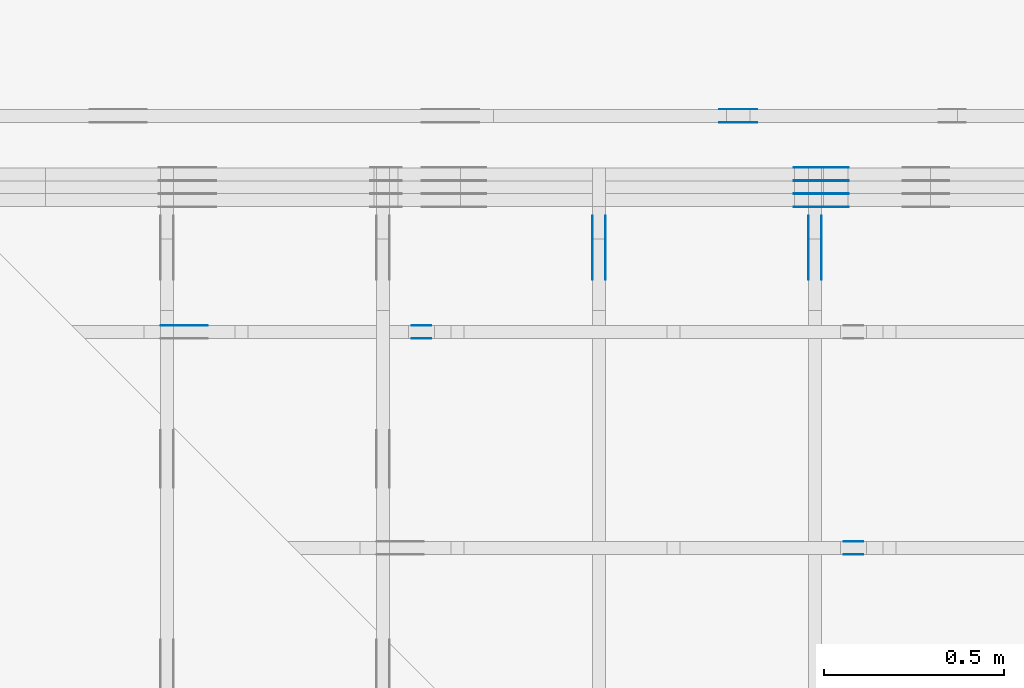
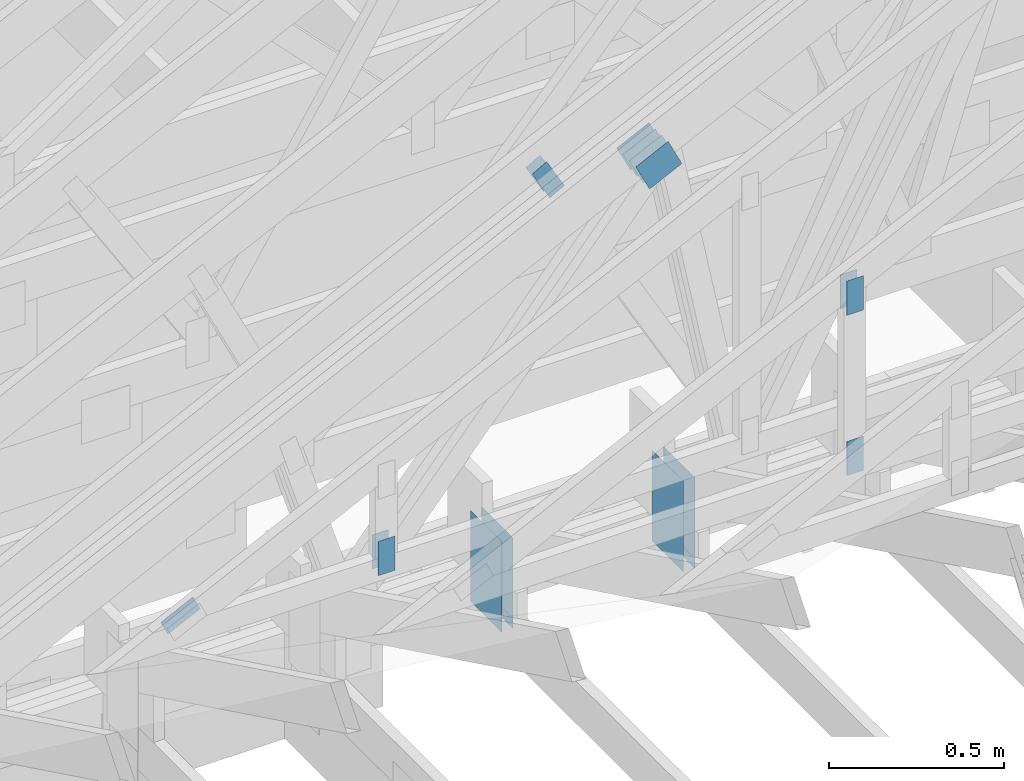
# One storey, part 101 of 159: 18 plates, 6 elements without a shape of their own.
"""IFC2X3 building model written with IfcOpenShell, lengths in millimetres."""

from ifc_helpers import new_model, si_unit, frame, origin, origin_with_axes, origin_2d, place, context, project, spatial, faceted_brep, element, aggregate, save


model = new_model("IFC2X3")

# Units and contexts
model_context = context("Model", 3, precision=1e-05, world=origin())
plan_context = context("Plan", 2, precision=1e-05, world=origin_2d())
ifc_project = project(units=[si_unit("LENGTHUNIT", "METRE", prefix="MILLI"), si_unit("AREAUNIT", "SQUARE_METRE"), si_unit("VOLUMEUNIT", "CUBIC_METRE"), si_unit("SOLIDANGLEUNIT", "STERADIAN"), si_unit("PLANEANGLEUNIT", "RADIAN"), si_unit("MASSUNIT", "GRAM"), si_unit("TIMEUNIT", "SECOND"), si_unit("THERMODYNAMICTEMPERATUREUNIT", "DEGREE_CELSIUS"), si_unit("LUMINOUSINTENSITYUNIT", "LUMEN")], contexts=[model_context, plan_context])

# Site, building, storey
site_placement = place(None, origin_with_axes())
site = spatial("IfcSite", under=ifc_project, at=site_placement, CompositionType="ELEMENT")
building_placement = place(site_placement, origin_with_axes())
building = spatial("IfcBuilding", under=site, at=building_placement, Name="Plan 1", CompositionType="ELEMENT")
storey_placement = place(building_placement, origin_with_axes())
storey = spatial("IfcBuildingStorey", under=building, at=storey_placement, Name="Etasje 1", CompositionType="ELEMENT", Elevation=0.0)

# Assembly, plates
assembly_1_placement = place(storey_placement, frame((10700.012663101485, 8801.999999990367, 0.0), z_axis=(0.0, -1.0, 6.123031769111886e-17), x_axis=(1.0, 0.0, 0.0)))
assembly_1 = element("IfcElementAssembly", 1, at=assembly_1_placement, inside=storey, Name="T8 (1)", AssemblyPlace="FACTORY", PredefinedType="TRUSS")
plate_1_placement = place(assembly_1_placement, frame((2640.9558752866787, 1642.1270385716039, 0.0), z_axis=(0.0, 0.0, 1.0), x_axis=(-0.898794046299167, -0.4383711467890773, 0.0)))
plate_1 = element("IfcPlate", 2, at=plate_1_placement, Name="GNT100S 103x119", context=model_context, shape_type="Brep", body=[
    faceted_brep([(119.00003363810492, 103.00011609094713, 1.0), (0.0, 103.00011609094713, 1.0), (9.564507581671933e-05, 4.841883696826699e-05, 1.0), (119.00012928318029, 4.841883696826699e-05, 1.0), (0.0, 103.00011609094713, 0.0), (119.00003363810492, 103.00011609094713, 1.457281972982999e-14), (119.00012928318029, 0.0, 1.457283144258669e-14), (9.564507581671933e-05, 0.0, 1.1712756755697749e-20), (119.00009903197406, 6.155786214402485e-05, 2.3173511314596367e-30), (119.00009903197406, 6.155786214408608e-05, 1.0), (9.903197405947138e-05, 6.155786195455884e-05, 1.0), (9.903197405947138e-05, 6.155786195449761e-05, 1.504632769052528e-36), (119.00009903197406, 103.00006155786218, 2.8398992587956425e-29), (119.00009903197406, 103.00006155786218, 1.0), (119.00009903197406, 6.155786218187131e-05, 1.0), (119.00009903197406, 6.155786218187131e-05, 0.0), (9.903197360472404e-05, 103.00006155786195, 0.0), (9.903197360472404e-05, 103.00006155786195, 1.0), (119.0000990319736, 103.00006155786218, 1.0), (119.0000990319736, 103.00006155786218, 7.888609052210118e-31), (9.90319740594714e-05, 6.155786195449763e-05, 0.0), (9.903197405953263e-05, 6.155786195449763e-05, 1.0), (9.903197361473418e-05, 103.00006155786195, 1.0), (9.903197361467295e-05, 103.00006155786195, -6.091754029916053e-31)], [[[0, 1, 2, 3]], [[4, 5, 6, 7]], [[8, 9, 10, 11]], [[12, 13, 14, 15]], [[16, 17, 18, 19]], [[20, 21, 22, 23]]]),
])
plate_2_placement = place(assembly_1_placement, frame((2640.9558752866787, 1642.1270385716039, -37.0), z_axis=(0.0, 0.0, 1.0), x_axis=(-0.898794046299167, -0.4383711467890773, 0.0)))
plate_2 = element("IfcPlate", 3, at=plate_2_placement, Name="GNT100S 103x119", context=model_context, shape_type="Brep", body=[
    faceted_brep([(119.00003363810492, 103.00011609094713, 1.0), (0.0, 103.00011609094713, 1.0), (9.564507581671933e-05, 4.841883696826699e-05, 1.0), (119.00012928318029, 4.841883696826699e-05, 1.0), (0.0, 103.00011609094713, 0.0), (119.00003363810492, 103.00011609094713, 1.457281972982999e-14), (119.00012928318029, 0.0, 1.457283144258669e-14), (9.564507581671933e-05, 0.0, 1.1712756755697749e-20), (119.00009903197406, 6.155786214402485e-05, 2.3173511314596367e-30), (119.00009903197406, 6.155786214408608e-05, 1.0), (9.903197405947138e-05, 6.155786195455884e-05, 1.0), (9.903197405947138e-05, 6.155786195449761e-05, 1.504632769052528e-36), (119.00009903197406, 103.00006155786218, 2.8398992587956425e-29), (119.00009903197406, 103.00006155786218, 1.0), (119.00009903197406, 6.155786218187131e-05, 1.0), (119.00009903197406, 6.155786218187131e-05, 0.0), (9.903197360472404e-05, 103.00006155786195, 0.0), (9.903197360472404e-05, 103.00006155786195, 1.0), (119.0000990319736, 103.00006155786218, 1.0), (119.0000990319736, 103.00006155786218, 7.888609052210118e-31), (9.90319740594714e-05, 6.155786195449763e-05, 0.0), (9.903197405953263e-05, 6.155786195449763e-05, 1.0), (9.903197361473418e-05, 103.00006155786195, 1.0), (9.903197361467295e-05, 103.00006155786195, -6.091754029916053e-31)], [[[0, 1, 2, 3]], [[4, 5, 6, 7]], [[8, 9, 10, 11]], [[12, 13, 14, 15]], [[16, 17, 18, 19]], [[20, 21, 22, 23]]]),
])
plate_3_placement = place(assembly_1_placement, frame((2640.9558752866787, 1642.1270385716039, -36.0), z_axis=(0.0, 0.0, 1.0), x_axis=(-0.898794046299167, -0.4383711467890773, 0.0)))
plate_3 = element("IfcPlate", 4, at=plate_3_placement, Name="GNT100S 103x119", context=model_context, shape_type="Brep", body=[
    faceted_brep([(119.00003363810492, 103.00011609094713, 1.0), (0.0, 103.00011609094713, 1.0), (9.564507581671933e-05, 4.841883696826699e-05, 1.0), (119.00012928318029, 4.841883696826699e-05, 1.0), (0.0, 103.00011609094713, 0.0), (119.00003363810492, 103.00011609094713, 1.457281972982999e-14), (119.00012928318029, 0.0, 1.457283144258669e-14), (9.564507581671933e-05, 0.0, 1.1712756755697749e-20), (119.00009903197406, 6.155786214402485e-05, 2.3173511314596367e-30), (119.00009903197406, 6.155786214408608e-05, 1.0), (9.903197405947138e-05, 6.155786195455884e-05, 1.0), (9.903197405947138e-05, 6.155786195449761e-05, 1.504632769052528e-36), (119.00009903197406, 103.00006155786218, 2.8398992587956425e-29), (119.00009903197406, 103.00006155786218, 1.0), (119.00009903197406, 6.155786218187131e-05, 1.0), (119.00009903197406, 6.155786218187131e-05, 0.0), (9.903197360472404e-05, 103.00006155786195, 0.0), (9.903197360472404e-05, 103.00006155786195, 1.0), (119.0000990319736, 103.00006155786218, 1.0), (119.0000990319736, 103.00006155786218, 7.888609052210118e-31), (9.90319740594714e-05, 6.155786195449763e-05, 0.0), (9.903197405953263e-05, 6.155786195449763e-05, 1.0), (9.903197361473418e-05, 103.00006155786195, 1.0), (9.903197361467295e-05, 103.00006155786195, -6.091754029916053e-31)], [[[0, 1, 2, 3]], [[4, 5, 6, 7]], [[8, 9, 10, 11]], [[12, 13, 14, 15]], [[16, 17, 18, 19]], [[20, 21, 22, 23]]]),
])
plate_4_placement = place(assembly_1_placement, frame((2640.9558752866787, 1642.1270385716039, -73.0), z_axis=(0.0, 0.0, 1.0), x_axis=(-0.898794046299167, -0.4383711467890773, 0.0)))
plate_4 = element("IfcPlate", 5, at=plate_4_placement, Name="GNT100S 103x119", context=model_context, shape_type="Brep", body=[
    faceted_brep([(119.00003363810492, 103.00011609094713, 1.0), (0.0, 103.00011609094713, 1.0), (9.564507581671933e-05, 4.841883696826699e-05, 1.0), (119.00012928318029, 4.841883696826699e-05, 1.0), (0.0, 103.00011609094713, 0.0), (119.00003363810492, 103.00011609094713, 1.457281972982999e-14), (119.00012928318029, 0.0, 1.457283144258669e-14), (9.564507581671933e-05, 0.0, 1.1712756755697749e-20), (119.00009903197406, 6.155786214402485e-05, 2.3173511314596367e-30), (119.00009903197406, 6.155786214408608e-05, 1.0), (9.903197405947138e-05, 6.155786195455884e-05, 1.0), (9.903197405947138e-05, 6.155786195449761e-05, 1.504632769052528e-36), (119.00009903197406, 103.00006155786218, 2.8398992587956425e-29), (119.00009903197406, 103.00006155786218, 1.0), (119.00009903197406, 6.155786218187131e-05, 1.0), (119.00009903197406, 6.155786218187131e-05, 0.0), (9.903197360472404e-05, 103.00006155786195, 0.0), (9.903197360472404e-05, 103.00006155786195, 1.0), (119.0000990319736, 103.00006155786218, 1.0), (119.0000990319736, 103.00006155786218, 7.888609052210118e-31), (9.90319740594714e-05, 6.155786195449763e-05, 0.0), (9.903197405953263e-05, 6.155786195449763e-05, 1.0), (9.903197361473418e-05, 103.00006155786195, 1.0), (9.903197361467295e-05, 103.00006155786195, -6.091754029916053e-31)], [[[0, 1, 2, 3]], [[4, 5, 6, 7]], [[8, 9, 10, 11]], [[12, 13, 14, 15]], [[16, 17, 18, 19]], [[20, 21, 22, 23]]]),
])
plate_5_placement = place(assembly_1_placement, frame((2640.9558752866787, 1642.1270385716039, -72.0), z_axis=(0.0, 0.0, 1.0), x_axis=(-0.898794046299167, -0.4383711467890773, 0.0)))
plate_5 = element("IfcPlate", 6, at=plate_5_placement, Name="GNT100S 103x119", context=model_context, shape_type="Brep", body=[
    faceted_brep([(119.00003363810492, 103.00011609094713, 1.0), (0.0, 103.00011609094713, 1.0), (9.564507581671933e-05, 4.841883696826699e-05, 1.0), (119.00012928318029, 4.841883696826699e-05, 1.0), (0.0, 103.00011609094713, 0.0), (119.00003363810492, 103.00011609094713, 1.457281972982999e-14), (119.00012928318029, 0.0, 1.457283144258669e-14), (9.564507581671933e-05, 0.0, 1.1712756755697749e-20), (119.00009903197406, 6.155786214402485e-05, 2.3173511314596367e-30), (119.00009903197406, 6.155786214408608e-05, 1.0), (9.903197405947138e-05, 6.155786195455884e-05, 1.0), (9.903197405947138e-05, 6.155786195449761e-05, 1.504632769052528e-36), (119.00009903197406, 103.00006155786218, 2.8398992587956425e-29), (119.00009903197406, 103.00006155786218, 1.0), (119.00009903197406, 6.155786218187131e-05, 1.0), (119.00009903197406, 6.155786218187131e-05, 0.0), (9.903197360472404e-05, 103.00006155786195, 0.0), (9.903197360472404e-05, 103.00006155786195, 1.0), (119.0000990319736, 103.00006155786218, 1.0), (119.0000990319736, 103.00006155786218, 7.888609052210118e-31), (9.90319740594714e-05, 6.155786195449763e-05, 0.0), (9.903197405953263e-05, 6.155786195449763e-05, 1.0), (9.903197361473418e-05, 103.00006155786195, 1.0), (9.903197361467295e-05, 103.00006155786195, -6.091754029916053e-31)], [[[0, 1, 2, 3]], [[4, 5, 6, 7]], [[8, 9, 10, 11]], [[12, 13, 14, 15]], [[16, 17, 18, 19]], [[20, 21, 22, 23]]]),
])
plate_6_placement = place(assembly_1_placement, frame((2640.9558752866787, 1642.1270385716039, -109.0), z_axis=(0.0, 0.0, 1.0), x_axis=(-0.898794046299167, -0.4383711467890773, 0.0)))
plate_6 = element("IfcPlate", 7, at=plate_6_placement, Name="GNT100S 103x119", context=model_context, shape_type="Brep", body=[
    faceted_brep([(119.00003363810492, 103.00011609094713, 1.0), (0.0, 103.00011609094713, 1.0), (9.564507581671933e-05, 4.841883696826699e-05, 1.0), (119.00012928318029, 4.841883696826699e-05, 1.0), (0.0, 103.00011609094713, 0.0), (119.00003363810492, 103.00011609094713, 1.457281972982999e-14), (119.00012928318029, 0.0, 1.457283144258669e-14), (9.564507581671933e-05, 0.0, 1.1712756755697749e-20), (119.00009903197406, 6.155786214402485e-05, 2.3173511314596367e-30), (119.00009903197406, 6.155786214408608e-05, 1.0), (9.903197405947138e-05, 6.155786195455884e-05, 1.0), (9.903197405947138e-05, 6.155786195449761e-05, 1.504632769052528e-36), (119.00009903197406, 103.00006155786218, 2.8398992587956425e-29), (119.00009903197406, 103.00006155786218, 1.0), (119.00009903197406, 6.155786218187131e-05, 1.0), (119.00009903197406, 6.155786218187131e-05, 0.0), (9.903197360472404e-05, 103.00006155786195, 0.0), (9.903197360472404e-05, 103.00006155786195, 1.0), (119.0000990319736, 103.00006155786218, 1.0), (119.0000990319736, 103.00006155786218, 7.888609052210118e-31), (9.90319740594714e-05, 6.155786195449763e-05, 0.0), (9.903197405953263e-05, 6.155786195449763e-05, 1.0), (9.903197361473418e-05, 103.00006155786195, 1.0), (9.903197361467295e-05, 103.00006155786195, -6.091754029916053e-31)], [[[0, 1, 2, 3]], [[4, 5, 6, 7]], [[8, 9, 10, 11]], [[12, 13, 14, 15]], [[16, 17, 18, 19]], [[20, 21, 22, 23]]]),
])
aggregate(assembly_1, [plate_1, plate_2, plate_3, plate_4, plate_5, plate_6])

assembly_2_placement = place(storey_placement, frame((10000.012663278096, 9072.000080051337, 1.1021457184401395e-15), z_axis=(9.811600543477555e-09, 1.0, 6.123031769111886e-17), x_axis=(-1.0, 9.811600543477555e-09, 0.0)))
assembly_2 = element("IfcElementAssembly", 8, at=assembly_2_placement, inside=storey, Name="T9 (79)", AssemblyPlace="FACTORY", PredefinedType="TRUSS")
plate_7_placement = place(assembly_2_placement, frame((-3074.84716796875, 1522.9232177734377, 0.0), z_axis=(0.0, 0.0, 1.0), x_axis=(-0.49048556678031596, -0.8714493150953716, 0.0)))
plate_7 = element("IfcPlate", 9, at=plate_7_placement, Name="GNT100S 55x119", context=model_context, shape_type="Brep", body=[
    faceted_brep([(118.99998125456682, 55.00002763965995, 1.0), (9.973139208341308e-05, 55.00002763965995, 1.0), (0.0, 0.0, 1.0), (118.99998790126483, 0.0, 1.0), (9.973139208341308e-05, 55.00002763965995, 1.221316964208984e-20), (118.99998125456682, 55.00002763965995, 1.457281331490863e-14), (118.99998790126483, 0.00011559060385479825, 1.4572814128867493e-14), (0.0, 0.00011559060385479825, 0.0), (119.00004852770257, 2.404680618485307e-05, -6.193572529397838e-31), (119.00004852770257, 2.40468061849143e-05, 1.0), (4.852770257457451e-05, 2.404680662954645e-05, 1.0), (4.852770257457451e-05, 2.404680662948522e-05, -3.76158192263132e-37), (119.00004852770257, 55.000024046806175, 0.0), (119.00004852770257, 55.000024046806175, 1.0), (119.00004852770257, 2.4046806174737867e-05, 1.0), (119.00004852770257, 2.4046806174737867e-05, 0.0), (4.85277025745745e-05, 55.00002404680663, 0.0), (4.85277025745745e-05, 55.00002404680663, 1.0), (119.00004852770257, 55.000024046806175, 1.0), (119.00004852770257, 55.000024046806175, -3.944304526105059e-31), (4.8527702574574505e-05, 2.4046806629485218e-05, 0.0), (4.8527702574635735e-05, 2.4046806629485218e-05, 1.0), (4.852770258137107e-05, 55.00002404680663, 1.0), (4.852770258130984e-05, 55.00002404680663, -4.12407052618761e-31)], [[[0, 1, 2, 3]], [[4, 5, 6, 7]], [[8, 9, 10, 11]], [[12, 13, 14, 15]], [[16, 17, 18, 19]], [[20, 21, 22, 23]]]),
])
plate_8_placement = place(assembly_2_placement, frame((-3074.84716796875, 1522.9232177734377, -37.0), z_axis=(0.0, 0.0, 1.0), x_axis=(-0.49048556678031596, -0.8714493150953716, 0.0)))
plate_8 = element("IfcPlate", 10, at=plate_8_placement, Name="GNT100S 55x119", context=model_context, shape_type="Brep", body=[
    faceted_brep([(118.99998125456682, 55.00002763965995, 1.0), (9.973139208341308e-05, 55.00002763965995, 1.0), (0.0, 0.0, 1.0), (118.99998790126483, 0.0, 1.0), (9.973139208341308e-05, 55.00002763965995, 1.221316964208984e-20), (118.99998125456682, 55.00002763965995, 1.457281331490863e-14), (118.99998790126483, 0.00011559060385479825, 1.4572814128867493e-14), (0.0, 0.00011559060385479825, 0.0), (119.00004852770257, 2.404680618485307e-05, -6.193572529397838e-31), (119.00004852770257, 2.40468061849143e-05, 1.0), (4.852770257457451e-05, 2.404680662954645e-05, 1.0), (4.852770257457451e-05, 2.404680662948522e-05, -3.76158192263132e-37), (119.00004852770257, 55.000024046806175, 0.0), (119.00004852770257, 55.000024046806175, 1.0), (119.00004852770257, 2.4046806174737867e-05, 1.0), (119.00004852770257, 2.4046806174737867e-05, 0.0), (4.85277025745745e-05, 55.00002404680663, 0.0), (4.85277025745745e-05, 55.00002404680663, 1.0), (119.00004852770257, 55.000024046806175, 1.0), (119.00004852770257, 55.000024046806175, -3.944304526105059e-31), (4.8527702574574505e-05, 2.4046806629485218e-05, 0.0), (4.8527702574635735e-05, 2.4046806629485218e-05, 1.0), (4.852770258137107e-05, 55.00002404680663, 1.0), (4.852770258130984e-05, 55.00002404680663, -4.12407052618761e-31)], [[[0, 1, 2, 3]], [[4, 5, 6, 7]], [[8, 9, 10, 11]], [[12, 13, 14, 15]], [[16, 17, 18, 19]], [[20, 21, 22, 23]]]),
])
aggregate(assembly_2, [plate_7, plate_8])

assembly_3_placement = place(storey_placement, frame((13275.022261404752, -699.9989301294836, 1.1021457184401395e-15), z_axis=(-1.0, 1.836909530733566e-16, 6.123031769111886e-17), x_axis=(-1.836909530733566e-16, -1.0, 0.0)))
assembly_3 = element("IfcElementAssembly", 11, at=assembly_3_placement, inside=storey, Name="T6 (100)", AssemblyPlace="FACTORY", PredefinedType="TRUSS")
plate_9_placement = place(assembly_3_placement, frame((-9477.154435624892, 601.947714222237, 0.0), z_axis=(0.0, 0.0, 1.0), x_axis=(2.6073089813474087e-12, -1.0, 0.0)))
plate_9 = element("IfcPlate", 12, at=plate_9_placement, Name="GNT100S 178x317", context=model_context, shape_type="Brep", body=[
    faceted_brep([(316.9999908340292, 178.00013874989236, 1.0), (2.1351607301767217e-05, 178.00013874989236, 1.0), (2.1351143232095637e-05, 0.00013874989235773683, 1.0), (316.99999083356505, 0.00013874989235773683, 1.0), (2.1351607301767217e-05, 178.00013874989236, 2.61473139660644e-21), (316.9999908340292, 178.00013874989236, 3.882002029369875e-14), (316.99999083356505, 0.0001387490647175582, 3.882002029364191e-14), (2.1351143232095637e-05, 0.0001387490647175582, 2.6146745663395966e-21), (317.00000000000006, -2.1010854189297505e-13, 1.286501276972462e-29), (317.00000000000006, -2.1004731157528393e-13, 1.0), (1.1368683772161603e-13, 1.8190506338635476e-12, 1.0), (1.1368683772161603e-13, 1.8189894035458565e-12, 0.0), (317.00000000000006, 178.0, 0.0), (317.00000000000006, 178.0, 1.0), (317.00000000000006, 0.0, 1.0), (317.00000000000006, 0.0, 0.0), (0.0, 178.00000000000182, 0.0), (0.0, 178.00000000000182, 1.0), (317.00000000000006, 177.99999999999997, 1.0), (317.00000000000006, 177.99999999999997, -1.5777218104420236e-30), (1.1368683772161664e-13, 1.8189894035458565e-12, -3.6433760072445244e-44), (1.1374806803930775e-13, 1.8189894035458565e-12, 1.0), (5.6498181784034924e-14, 178.00000000000182, 1.0), (5.6436951466343805e-14, 178.00000000000182, -3.455652467802488e-30)], [[[0, 1, 2, 3]], [[4, 5, 6, 7]], [[8, 9, 10, 11]], [[12, 13, 14, 15]], [[16, 17, 18, 19]], [[20, 21, 22, 23]]]),
])
plate_10_placement = place(assembly_3_placement, frame((-9477.154435624892, 601.947714222237, -37.0), z_axis=(0.0, 0.0, 1.0), x_axis=(2.6073089813474087e-12, -1.0, 0.0)))
plate_10 = element("IfcPlate", 13, at=plate_10_placement, Name="GNT100S 178x317", context=model_context, shape_type="Brep", body=[
    faceted_brep([(316.9999908340292, 178.00013874989236, 1.0), (2.1351607301767217e-05, 178.00013874989236, 1.0), (2.1351143232095637e-05, 0.00013874989235773683, 1.0), (316.99999083356505, 0.00013874989235773683, 1.0), (2.1351607301767217e-05, 178.00013874989236, 2.61473139660644e-21), (316.9999908340292, 178.00013874989236, 3.882002029369875e-14), (316.99999083356505, 0.0001387490647175582, 3.882002029364191e-14), (2.1351143232095637e-05, 0.0001387490647175582, 2.6146745663395966e-21), (317.00000000000006, -2.1010854189297505e-13, 1.286501276972462e-29), (317.00000000000006, -2.1004731157528393e-13, 1.0), (1.1368683772161603e-13, 1.8190506338635476e-12, 1.0), (1.1368683772161603e-13, 1.8189894035458565e-12, 0.0), (317.00000000000006, 178.0, 0.0), (317.00000000000006, 178.0, 1.0), (317.00000000000006, 0.0, 1.0), (317.00000000000006, 0.0, 0.0), (0.0, 178.00000000000182, 0.0), (0.0, 178.00000000000182, 1.0), (317.00000000000006, 177.99999999999997, 1.0), (317.00000000000006, 177.99999999999997, -1.5777218104420236e-30), (1.1368683772161664e-13, 1.8189894035458565e-12, -3.6433760072445244e-44), (1.1374806803930775e-13, 1.8189894035458565e-12, 1.0), (5.6498181784034924e-14, 178.00000000000182, 1.0), (5.6436951466343805e-14, 178.00000000000182, -3.455652467802488e-30)], [[[0, 1, 2, 3]], [[4, 5, 6, 7]], [[8, 9, 10, 11]], [[12, 13, 14, 15]], [[16, 17, 18, 19]], [[20, 21, 22, 23]]]),
])
aggregate(assembly_3, [plate_9, plate_10])

assembly_4_placement = place(storey_placement, frame((12675.022261404752, -699.9989301294854, 4.558494966049043e-13), z_axis=(-1.0, 1.836909530733566e-16, 6.123031769111886e-17), x_axis=(-1.836909530733566e-16, -1.0, 0.0)))
assembly_4 = element("IfcElementAssembly", 14, at=assembly_4_placement, inside=storey, Name="T6 (99)", AssemblyPlace="FACTORY", PredefinedType="TRUSS")
plate_11_placement = place(assembly_4_placement, frame((-9477.154435624892, 601.947714222237, 0.0), z_axis=(0.0, 0.0, 1.0), x_axis=(2.6073089813474087e-12, -1.0, 0.0)))
plate_11 = element("IfcPlate", 15, at=plate_11_placement, Name="GNT100S 178x317", context=model_context, shape_type="Brep", body=[
    faceted_brep([(316.9999908340292, 178.00013874989236, 1.0), (2.1351607301767217e-05, 178.00013874989236, 1.0), (2.1351143232095637e-05, 0.00013874989235773683, 1.0), (316.99999083356505, 0.00013874989235773683, 1.0), (2.1351607301767217e-05, 178.00013874989236, 2.61473139660644e-21), (316.9999908340292, 178.00013874989236, 3.882002029369875e-14), (316.99999083356505, 0.0001387490647175582, 3.882002029364191e-14), (2.1351143232095637e-05, 0.0001387490647175582, 2.6146745663395966e-21), (317.00000000000006, -2.1010854189297505e-13, 1.286501276972462e-29), (317.00000000000006, -2.1004731157528393e-13, 1.0), (1.1368683772161603e-13, 1.8190506338635476e-12, 1.0), (1.1368683772161603e-13, 1.8189894035458565e-12, 0.0), (317.00000000000006, 178.0, 0.0), (317.00000000000006, 178.0, 1.0), (317.00000000000006, 0.0, 1.0), (317.00000000000006, 0.0, 0.0), (0.0, 178.00000000000182, 0.0), (0.0, 178.00000000000182, 1.0), (317.00000000000006, 177.99999999999997, 1.0), (317.00000000000006, 177.99999999999997, -1.5777218104420236e-30), (1.1368683772161664e-13, 1.8189894035458565e-12, -3.6433760072445244e-44), (1.1374806803930775e-13, 1.8189894035458565e-12, 1.0), (5.6498181784034924e-14, 178.00000000000182, 1.0), (5.6436951466343805e-14, 178.00000000000182, -3.455652467802488e-30)], [[[0, 1, 2, 3]], [[4, 5, 6, 7]], [[8, 9, 10, 11]], [[12, 13, 14, 15]], [[16, 17, 18, 19]], [[20, 21, 22, 23]]]),
])
plate_12_placement = place(assembly_4_placement, frame((-9477.154435624892, 601.947714222237, -37.0), z_axis=(0.0, 0.0, 1.0), x_axis=(2.6073089813474087e-12, -1.0, 0.0)))
plate_12 = element("IfcPlate", 16, at=plate_12_placement, Name="GNT100S 178x317", context=model_context, shape_type="Brep", body=[
    faceted_brep([(316.9999908340292, 178.00013874989236, 1.0), (2.1351607301767217e-05, 178.00013874989236, 1.0), (2.1351143232095637e-05, 0.00013874989235773683, 1.0), (316.99999083356505, 0.00013874989235773683, 1.0), (2.1351607301767217e-05, 178.00013874989236, 2.61473139660644e-21), (316.9999908340292, 178.00013874989236, 3.882002029369875e-14), (316.99999083356505, 0.0001387490647175582, 3.882002029364191e-14), (2.1351143232095637e-05, 0.0001387490647175582, 2.6146745663395966e-21), (317.00000000000006, -2.1010854189297505e-13, 1.286501276972462e-29), (317.00000000000006, -2.1004731157528393e-13, 1.0), (1.1368683772161603e-13, 1.8190506338635476e-12, 1.0), (1.1368683772161603e-13, 1.8189894035458565e-12, 0.0), (317.00000000000006, 178.0, 0.0), (317.00000000000006, 178.0, 1.0), (317.00000000000006, 0.0, 1.0), (317.00000000000006, 0.0, 0.0), (0.0, 178.00000000000182, 0.0), (0.0, 178.00000000000182, 1.0), (317.00000000000006, 177.99999999999997, 1.0), (317.00000000000006, 177.99999999999997, -1.5777218104420236e-30), (1.1368683772161664e-13, 1.8189894035458565e-12, -3.6433760072445244e-44), (1.1374806803930775e-13, 1.8189894035458565e-12, 1.0), (5.6498181784034924e-14, 178.00000000000182, 1.0), (5.6436951466343805e-14, 178.00000000000182, -3.455652467802488e-30)], [[[0, 1, 2, 3]], [[4, 5, 6, 7]], [[8, 9, 10, 11]], [[12, 13, 14, 15]], [[16, 17, 18, 19]], [[20, 21, 22, 23]]]),
])
aggregate(assembly_4, [plate_11, plate_12])

assembly_5_placement = place(storey_placement, frame((11246.01259527543, 8436.00006782605, 727.7147722720857), z_axis=(0.0, -1.0, 6.123031769111886e-17), x_axis=(1.0, 0.0, 0.0)))
assembly_5 = element("IfcElementAssembly", 17, at=assembly_5_placement, inside=storey, Name="Tr1 (1)", AssemblyPlace="FACTORY", PredefinedType="TRUSS")
plate_13_placement = place(assembly_5_placement, frame((253.2841968538207, 38.42090597057235, -37.00000000000001), z_axis=(0.0, 0.0, 1.0), x_axis=(0.898794046299167, 0.4383711467890774, 0.0)))
plate_13 = element("IfcPlate", 18, at=plate_13_placement, Name="GNT100S 55x119", context=model_context, shape_type="Brep", body=[
    faceted_brep([(119.00000687542453, 55.00000532224293, 1.0), (1.0028205394974066e-06, 55.00000532224293, 1.0), (0.0, 4.3514078242878895e-06, 1.0), (119.00000420035079, 4.3514078242878895e-06, 1.0), (1.0028205394974066e-06, 55.00000532224293, 1.2280604044121083e-22), (119.00000687542453, 55.00000532224293, 1.4572816452455147e-14), (119.00000420035079, 0.0, 1.4572816124863917e-14), (0.0, 0.0, 0.0), (119.00000339135065, 2.2982145319160998e-06, 2.2085824040791803e-30), (119.00000339135065, 2.29821453197733e-06, 1.0), (3.391350674064597e-06, 2.2982145538365535e-06, 1.0), (3.391350674064597e-06, 2.298214553775323e-06, 7.052966104933725e-38), (119.00000339135065, 55.00000229821458, 0.0), (119.00000339135065, 55.00000229821458, 1.0), (119.00000339135065, 2.2982145679861787e-06, 1.0), (119.00000339135065, 2.2982145679861787e-06, 0.0), (3.391350674064597e-06, 55.00000229821457, 0.0), (3.391350674064597e-06, 55.00000229821457, 1.0), (119.00000339135066, 55.00000229821459, 1.0), (119.00000339135066, 55.00000229821459, 3.944304526105059e-31), (3.3913506740645975e-06, 2.298214553775324e-06, -2.350988701644575e-38), (3.391350674125828e-06, 2.298214553775324e-06, 1.0), (3.391350680861163e-06, 55.00000229821457, 1.0), (3.3913506807999325e-06, 55.00000229821457, -4.1240672348034275e-31)], [[[0, 1, 2, 3]], [[4, 5, 6, 7]], [[8, 9, 10, 11]], [[12, 13, 14, 15]], [[16, 17, 18, 19]], [[20, 21, 22, 23]]]),
])
plate_14_placement = place(assembly_5_placement, frame((981.500067826054, 29.720829010009762, 0.0), z_axis=(0.0, 0.0, 1.0), x_axis=(6.123031769111886e-17, 1.0, 0.0)))
plate_14 = element("IfcPlate", 19, at=plate_14_placement, Name="GNT100S 55x119", context=model_context, shape_type="Brep", body=[
    faceted_brep([(118.99999618530273, 55.000006790897714, 1.0), (0.0, 55.000006790897714, 1.0), (3.552713678800501e-15, 6.790897714381572e-06, 1.0), (118.99999618530273, 6.790897714381572e-06, 1.0), (0.0, 55.000006790897714, 0.0), (118.99999618530273, 55.000006790897714, 1.457281514333604e-14), (118.99999618530273, 6.790897714381572e-06, 1.457281514333604e-14), (3.552713678800501e-15, 6.790897714381572e-06, 4.350675744370766e-31), (119.00000002042088, -2.1859223419480565e-14, 1.3384471944559406e-30), (119.00000002042088, -2.1797993101789447e-14, 1.0), (2.042087388076652e-08, 6.123031393998908e-17, 1.0), (2.042087388076652e-08, -3.751129785748816e-24, 2.2968286848201866e-40), (119.00000002042088, 55.0, 0.0), (119.00000002042088, 55.0, 1.0), (119.00000002042088, 0.0, 1.0), (119.00000002042088, 0.0, 0.0), (2.042087388076652e-08, 55.0, 0.0), (2.042087388076652e-08, 55.0, 1.0), (119.00000002042088, 54.99999999999999, 1.0), (119.00000002042088, 54.99999999999999, -3.944304526105059e-31), (2.042087388076652e-08, 0.0, 0.0), (2.042087394199684e-08, -7.498303609110687e-33, 1.0), (2.0420880677331785e-08, 55.0, 1.0), (2.0420880616101467e-08, 55.0, -4.124066985010878e-31)], [[[0, 1, 2, 3]], [[4, 5, 6, 7]], [[8, 9, 10, 11]], [[12, 13, 14, 15]], [[16, 17, 18, 19]], [[20, 21, 22, 23]]]),
])
plate_15_placement = place(assembly_5_placement, frame((981.500067826054, 29.720829010009762, -37.0), z_axis=(0.0, 0.0, 1.0), x_axis=(6.123031769111886e-17, 1.0, 0.0)))
plate_15 = element("IfcPlate", 20, at=plate_15_placement, Name="GNT100S 55x119", context=model_context, shape_type="Brep", body=[
    faceted_brep([(118.99999618530273, 55.000006790897714, 1.0), (0.0, 55.000006790897714, 1.0), (3.552713678800501e-15, 6.790897714381572e-06, 1.0), (118.99999618530273, 6.790897714381572e-06, 1.0), (0.0, 55.000006790897714, 0.0), (118.99999618530273, 55.000006790897714, 1.457281514333604e-14), (118.99999618530273, 6.790897714381572e-06, 1.457281514333604e-14), (3.552713678800501e-15, 6.790897714381572e-06, 4.350675744370766e-31), (119.00000002042088, -2.1859223419480565e-14, 1.3384471944559406e-30), (119.00000002042088, -2.1797993101789447e-14, 1.0), (2.042087388076652e-08, 6.123031393998908e-17, 1.0), (2.042087388076652e-08, -3.751129785748816e-24, 2.2968286848201866e-40), (119.00000002042088, 55.0, 0.0), (119.00000002042088, 55.0, 1.0), (119.00000002042088, 0.0, 1.0), (119.00000002042088, 0.0, 0.0), (2.042087388076652e-08, 55.0, 0.0), (2.042087388076652e-08, 55.0, 1.0), (119.00000002042088, 54.99999999999999, 1.0), (119.00000002042088, 54.99999999999999, -3.944304526105059e-31), (2.042087388076652e-08, 0.0, 0.0), (2.042087394199684e-08, -7.498303609110687e-33, 1.0), (2.0420880677331785e-08, 55.0, 1.0), (2.0420880616101467e-08, 55.0, -4.124066985010878e-31)], [[[0, 1, 2, 3]], [[4, 5, 6, 7]], [[8, 9, 10, 11]], [[12, 13, 14, 15]], [[16, 17, 18, 19]], [[20, 21, 22, 23]]]),
])
aggregate(assembly_5, [plate_13, plate_14, plate_15])

assembly_6_placement = place(storey_placement, frame((11846.012601162385, 7836.000061939094, 1020.3543282828622), z_axis=(0.0, -1.0, 6.123031769111886e-17), x_axis=(1.0, 0.0, 0.0)))
assembly_6 = element("IfcElementAssembly", 21, at=assembly_6_placement, inside=storey, Name="Tr2 (1)", AssemblyPlace="FACTORY", PredefinedType="TRUSS")
plate_16_placement = place(assembly_6_placement, frame((1526.5000619390983, 708.4014892578125, 0.0), z_axis=(0.0, 0.0, 1.0), x_axis=(9.49408737391244e-16, -1.0, 0.0)))
plate_16 = element("IfcPlate", 22, at=plate_16_placement, Name="GNT100S 55x119", context=model_context, shape_type="Brep", body=[
    faceted_brep([(119.0, 55.00006013121424, 1.0), (0.0, 55.00006013121424, 1.0), (0.0, 6.013121424075507e-05, 1.0), (119.0, 6.013121424075507e-05, 1.0), (0.0, 55.00006013121424, 0.0), (119.0, 55.00006013121424, 1.457281561048629e-14), (119.0, 6.0131214013381395e-05, 1.457281561048629e-14), (0.0, 6.0131214013381395e-05, 0.0), (119.00000658267379, -5.87201218594683e-15, 3.5954517163164663e-31), (119.00000658267379, -5.810781868255711e-15, 1.0), (6.582673790944682e-06, 2.2743490543610353e-13, 1.0), (6.582673790944682e-06, 2.2737367511841238e-13, 1.988881127296249e-38), (119.00000658267379, 55.0, 0.0), (119.00000658267379, 55.0, 1.0), (119.00000658267379, 0.0, 1.0), (119.00000658267379, 0.0, 0.0), (6.582673790944682e-06, 55.00000000000023, 0.0), (6.582673790944682e-06, 55.00000000000023, 1.0), (119.00000658267379, 55.00000000000001, 1.0), (119.00000658267379, 55.00000000000001, 3.944304526105059e-31), (6.582673790944682e-06, 2.2737367544323206e-13, 0.0), (6.582673791005912e-06, 2.2737367544323206e-13, 1.0), (6.582673797741247e-06, 55.00000000000023, 1.0), (6.582673797680017e-06, 55.00000000000023, -4.124066764605687e-31)], [[[0, 1, 2, 3]], [[4, 5, 6, 7]], [[8, 9, 10, 11]], [[12, 13, 14, 15]], [[16, 17, 18, 19]], [[20, 21, 22, 23]]]),
])
plate_17_placement = place(assembly_6_placement, frame((1526.5000619390983, 708.4014892578125, -37.0), z_axis=(0.0, 0.0, 1.0), x_axis=(9.49408737391244e-16, -1.0, 0.0)))
plate_17 = element("IfcPlate", 23, at=plate_17_placement, Name="GNT100S 55x119", context=model_context, shape_type="Brep", body=[
    faceted_brep([(119.0, 55.00006013121424, 1.0), (0.0, 55.00006013121424, 1.0), (0.0, 6.013121424075507e-05, 1.0), (119.0, 6.013121424075507e-05, 1.0), (0.0, 55.00006013121424, 0.0), (119.0, 55.00006013121424, 1.457281561048629e-14), (119.0, 6.0131214013381395e-05, 1.457281561048629e-14), (0.0, 6.0131214013381395e-05, 0.0), (119.00000658267379, -5.87201218594683e-15, 3.5954517163164663e-31), (119.00000658267379, -5.810781868255711e-15, 1.0), (6.582673790944682e-06, 2.2743490543610353e-13, 1.0), (6.582673790944682e-06, 2.2737367511841238e-13, 1.988881127296249e-38), (119.00000658267379, 55.0, 0.0), (119.00000658267379, 55.0, 1.0), (119.00000658267379, 0.0, 1.0), (119.00000658267379, 0.0, 0.0), (6.582673790944682e-06, 55.00000000000023, 0.0), (6.582673790944682e-06, 55.00000000000023, 1.0), (119.00000658267379, 55.00000000000001, 1.0), (119.00000658267379, 55.00000000000001, 3.944304526105059e-31), (6.582673790944682e-06, 2.2737367544323206e-13, 0.0), (6.582673791005912e-06, 2.2737367544323206e-13, 1.0), (6.582673797741247e-06, 55.00000000000023, 1.0), (6.582673797680017e-06, 55.00000000000023, -4.124066764605687e-31)], [[[0, 1, 2, 3]], [[4, 5, 6, 7]], [[8, 9, 10, 11]], [[12, 13, 14, 15]], [[16, 17, 18, 19]], [[20, 21, 22, 23]]]),
])
plate_18_placement = place(assembly_6_placement, frame((1581.5001220703127, 29.720829010009766, 0.0), z_axis=(0.0, 0.0, 1.0), x_axis=(-1.0489927069340377e-15, 1.0, 0.0)))
plate_18 = element("IfcPlate", 24, at=plate_18_placement, Name="GNT100S 55x119", context=model_context, shape_type="Brep", body=[
    faceted_brep([(118.9999961853028, 55.00000000000023, 1.0), (5.684341886080802e-14, 55.00000000000023, 1.0), (0.0, 2.2737367544323206e-13, 1.0), (118.99999618530275, 2.2737367544323206e-13, 1.0), (5.684341886080802e-14, 55.00000000000023, 6.961081190993225e-30), (118.9999961853028, 55.00000000000023, 1.4572815143336048e-14), (118.99999618530275, 0.0, 1.4572815143336042e-14), (0.0, 0.0, 0.0), (119.00000002035226, 6.01312146736432e-05, 1.3384468320270608e-30), (119.00000002035226, 6.013121467370443e-05, 1.0), (2.0352246110633132e-08, 6.013121469556365e-05, 1.0), (2.0352246110633132e-08, 6.013121469550242e-05, 0.0), (119.00000002035226, 55.000060131214696, 0.0), (119.00000002035226, 55.000060131214696, 1.0), (119.00000002035226, 6.013121469550242e-05, 1.0), (119.00000002035226, 6.013121469550242e-05, 0.0), (2.0352246110633132e-08, 55.000060131214696, 0.0), (2.0352246110633132e-08, 55.000060131214696, 1.0), (119.00000002035226, 55.00006013121469, 1.0), (119.00000002035226, 55.00006013121469, -3.944304526105059e-31), (2.0352246110640497e-08, 6.013121469550242e-05, -4.5091228613573685e-37), (2.0352246171870815e-08, 6.013121469550242e-05, 1.0), (2.035225290720576e-08, 55.000060131214696, 1.0), (2.0352252845975443e-08, 55.000060131214696, -4.124071494133739e-31)], [[[0, 1, 2, 3]], [[4, 5, 6, 7]], [[8, 9, 10, 11]], [[12, 13, 14, 15]], [[16, 17, 18, 19]], [[20, 21, 22, 23]]]),
])
aggregate(assembly_6, [plate_16, plate_17, plate_18])

save(model, "model.ifc")
